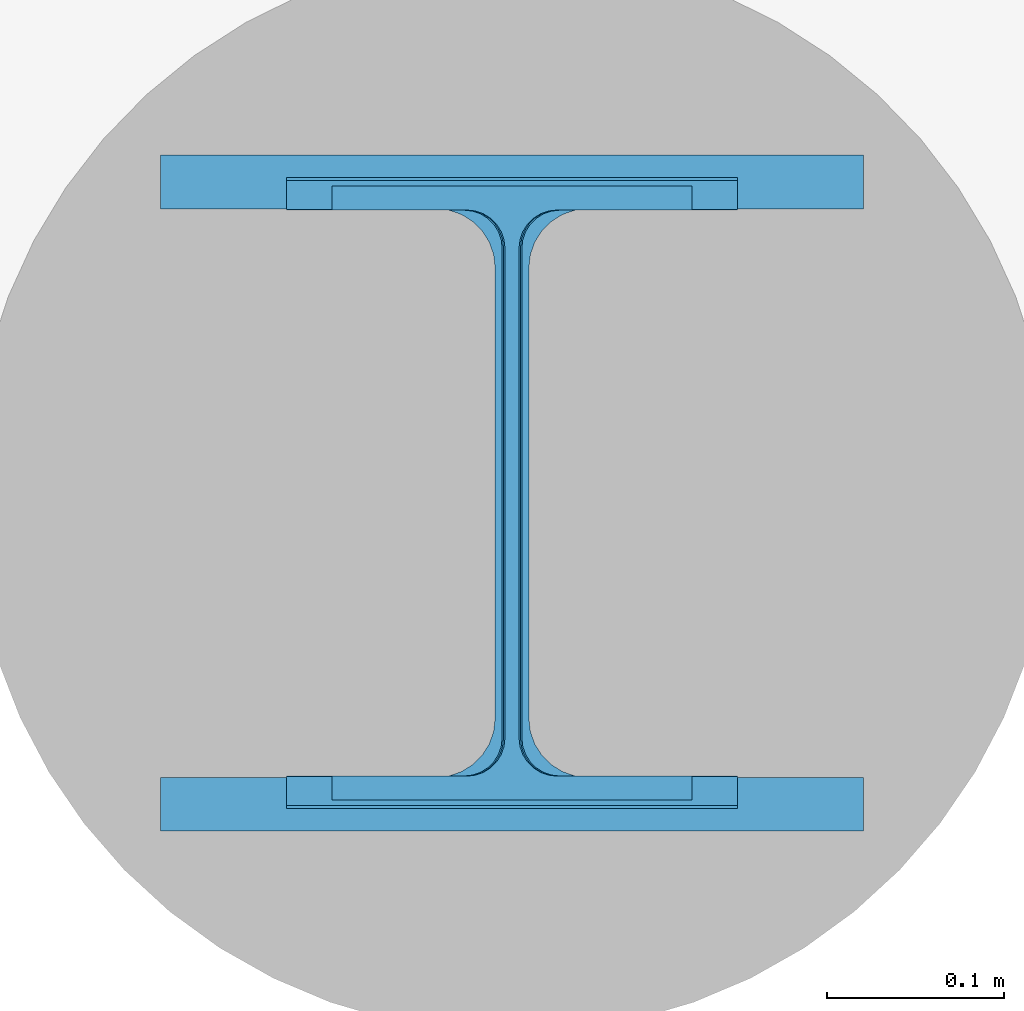
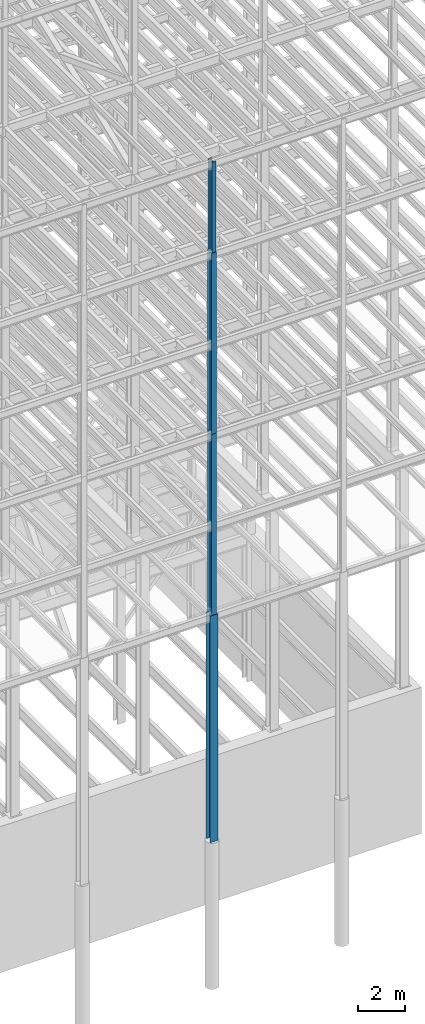
# One storey, part 74 of 150: 4 columns.
"""IFC2X3 building model written with IfcOpenShell, lengths in millimetres."""

from ifc_helpers import new_model, si_unit, frame, origin_with_axes, origin_2d_with_axis, place, context, subcontext, project, spatial, i_section, extrude, material, type_object, element, save


model = new_model("IFC2X3")

# Units and contexts
model_context = context("Model", 3, precision=1e-05, world=origin_with_axes())
body_context = subcontext(model_context, "Body", "Model", "MODEL_VIEW")
ifc_project = project(units=[si_unit("LENGTHUNIT", "METRE", prefix="MILLI"), si_unit("AREAUNIT", "SQUARE_METRE"), si_unit("VOLUMEUNIT", "CUBIC_METRE"), si_unit("MASSUNIT", "GRAM", prefix="KILO"), si_unit("TIMEUNIT", "SECOND"), si_unit("PLANEANGLEUNIT", "RADIAN"), si_unit("SOLIDANGLEUNIT", "STERADIAN"), si_unit("THERMODYNAMICTEMPERATUREUNIT", "DEGREE_CELSIUS"), si_unit("LUMINOUSINTENSITYUNIT", "LUMEN")], contexts=[model_context])

# Site, building, storey
site_placement = place(None, origin_with_axes())
site = spatial("IfcSite", under=ifc_project, at=site_placement, CompositionType="ELEMENT")
building_placement = place(site_placement, origin_with_axes())
building = spatial("IfcBuilding", under=site, at=building_placement, Name="Undefined", CompositionType="ELEMENT")
storey_placement = place(building_placement, origin_with_axes())
storey = spatial("IfcBuildingStorey", under=building, at=storey_placement, Name="Undefined", CompositionType="ELEMENT", Elevation=0.0)

# Columns
ifc_material = material(Name="STEEL/A992")
column_type_1 = type_object("IfcColumnType", Name="W14X43", PredefinedType="NOTDEFINED")
column_1_placement = place(storey_placement, frame((75793.6, 3454.40000000001, 54483.0), z_axis=(0.0, 0.0, 1.0), x_axis=(1.0, 0.0, 0.0)))
element("IfcColumn", 1, at=column_1_placement, inside=storey, type_object=column_type_1, material=ifc_material, Name="COLUMN", ObjectType="W14X43", context=body_context, shape_type="SweptSolid", body=[
    extrude(i_section(OverallWidth=203.2, OverallDepth=346.075, WebThickness=7.9375, FlangeThickness=13.462, FilletRadius=21.4629, at=origin_2d_with_axis()), frame((0.0, 0.0, 4724.39999999999), z_axis=(0.0, 0.0, -1.0), x_axis=(-1.0, 0.0, 0.0)), (0.0, 0.0, 1.0), 4724.4),
])
column_type_2 = type_object("IfcColumnType", Name="W14X61", PredefinedType="NOTDEFINED")
column_2_placement = place(storey_placement, frame((75793.6, 3454.40000000001, 45034.2), z_axis=(0.0, 0.0, 1.0), x_axis=(1.0, 0.0, 0.0)))
element("IfcColumn", 2, at=column_2_placement, inside=storey, type_object=column_type_2, material=ifc_material, Name="COLUMN", ObjectType="W14X61", context=body_context, shape_type="SweptSolid", body=[
    extrude(i_section(OverallWidth=254.0, OverallDepth=352.425, WebThickness=9.5249, FlangeThickness=16.383, FilletRadius=21.717, at=origin_2d_with_axis()), frame((0.0, 0.0, 9448.8), z_axis=(0.0, 0.0, -1.0), x_axis=(-1.0, 0.0, 0.0)), (0.0, 0.0, 1.0), 9448.8),
])
column_type_3 = type_object("IfcColumnType", Name="W14X68", PredefinedType="NOTDEFINED")
column_3_placement = place(storey_placement, frame((75793.6, 3454.40000000001, 35585.4), z_axis=(0.0, 0.0, 1.0), x_axis=(1.0, 0.0, 0.0)))
element("IfcColumn", 3, at=column_3_placement, inside=storey, type_object=column_type_3, material=ifc_material, Name="COLUMN", ObjectType="W14X68", context=body_context, shape_type="SweptSolid", body=[
    extrude(i_section(OverallWidth=254.0, OverallDepth=355.6, WebThickness=11.1125, FlangeThickness=18.288, FilletRadius=21.3994, at=origin_2d_with_axis()), frame((0.0, 0.0, 9448.8), z_axis=(0.0, 0.0, -1.0), x_axis=(-1.0, 0.0, 0.0)), (0.0, 0.0, 1.0), 9448.8),
])
column_type_4 = type_object("IfcColumnType", Name="W14X159", PredefinedType="NOTDEFINED")
column_4_placement = place(storey_placement, frame((75793.6, 3454.40000000001, 23774.4), z_axis=(0.0, 0.0, 1.0), x_axis=(1.0, 0.0, 0.0)))
element("IfcColumn", 4, at=column_4_placement, inside=storey, type_object=column_type_4, material=ifc_material, Name="COLUMN", ObjectType="W14X159", context=body_context, shape_type="SweptSolid", body=[
    extrude(i_section(OverallWidth=396.24, OverallDepth=381.0, WebThickness=19.0499, FlangeThickness=30.226, FilletRadius=33.2739, at=origin_2d_with_axis()), frame((0.0, 0.0, 11810.9988189), z_axis=(0.0, 0.0, -1.0), x_axis=(-1.0, 0.0, 0.0)), (0.0, 0.0, 1.0), 11810.9988189),
])

save(model, "model.ifc")
